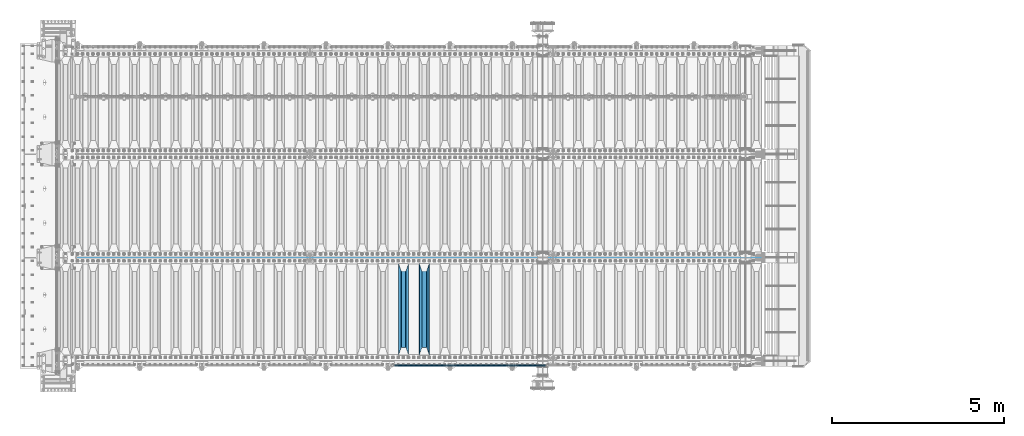
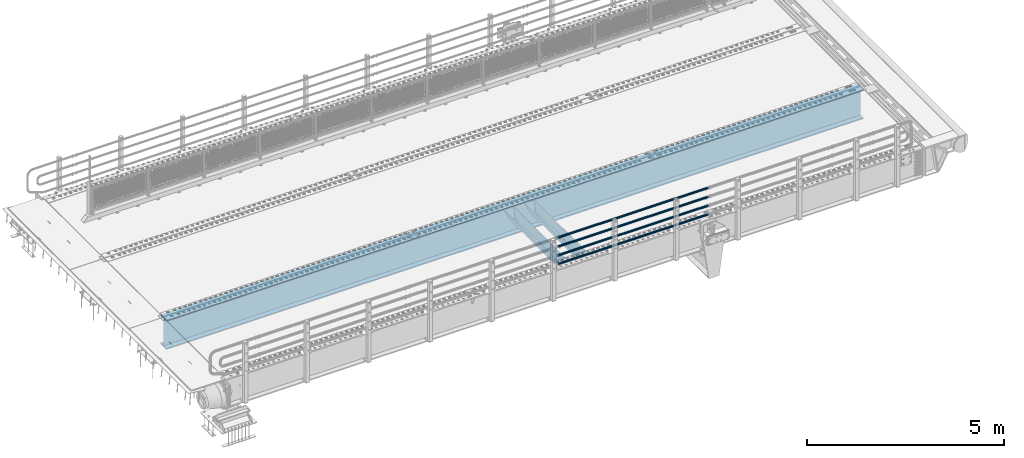
# One storey, part 122 of 270: 7 beams.
"""IFC2X3 building model written with IfcOpenShell, lengths in millimetres."""

from ifc_helpers import new_model, si_unit, frame, origin_with_axes, place, context, subcontext, project, spatial, faceted_brep, material, type_object, element, save


model = new_model("IFC2X3")

# Units and contexts
model_context = context("Model", 3, precision=1e-05, world=origin_with_axes())
body_context = subcontext(model_context, "Body", "Model", "MODEL_VIEW")
ifc_project = project(units=[si_unit("LENGTHUNIT", "METRE", prefix="MILLI"), si_unit("AREAUNIT", "SQUARE_METRE"), si_unit("VOLUMEUNIT", "CUBIC_METRE"), si_unit("MASSUNIT", "GRAM", prefix="KILO"), si_unit("TIMEUNIT", "SECOND"), si_unit("PLANEANGLEUNIT", "RADIAN"), si_unit("SOLIDANGLEUNIT", "STERADIAN"), si_unit("THERMODYNAMICTEMPERATUREUNIT", "DEGREE_CELSIUS"), si_unit("LUMINOUSINTENSITYUNIT", "LUMEN")], contexts=[model_context])

# Site, building, storey
site_placement = place(None, origin_with_axes())
site = spatial("IfcSite", under=ifc_project, at=site_placement, CompositionType="ELEMENT")
building_placement = place(site_placement, origin_with_axes())
building = spatial("IfcBuilding", under=site, at=building_placement, Name="Standard", CompositionType="ELEMENT")
storey_placement = place(building_placement, origin_with_axes())
storey = spatial("IfcBuildingStorey", under=building, at=storey_placement, Name="Undefined", CompositionType="ELEMENT", Elevation=0.0)

# Beams
ifc_material_1 = material()
beam_type_1 = type_object("IfcBeamType", PredefinedType="NOTDEFINED")
beam_1_placement = place(storey_placement, frame((14121.9999999999, -24129.8499999998, 149.849999999726), z_axis=(0.0, 0.0, -1.0), x_axis=(-1.0, 0.0, 0.0)))
element("IfcBeam", 1, at=beam_1_placement, inside=storey, type_object=beam_type_1, material=ifc_material_1, context=body_context, shape_type="Brep", body=[
    faceted_brep([(0.0, -26.5499999999993, 0.0), (0.0, -24.5290015881747, 10.1602451292931), (4384.0, -24.5290015881747, 10.1602451292931), (4384.0, -26.5499999999993, 0.0), (0.0, -18.7736850405036, 18.7736850405028), (4384.0, -18.7736850405036, 18.7736850405028), (0.0, -10.1602451292929, 24.5290015881747), (4384.0, -10.1602451292929, 24.5290015881747), (0.0, 0.0, 26.55), (4384.0, 0.0, 26.55), (0.0, 10.1602451292929, 24.5290015881747), (4384.0, 10.1602451292929, 24.5290015881747), (0.0, 18.7736850405036, 18.7736850405028), (4384.0, 18.7736850405036, 18.7736850405028), (0.0, 24.5290015881747, 10.1602451292931), (4384.0, 24.5290015881747, 10.1602451292931), (0.0, 26.5499999999993, 0.0), (4384.0, 26.5499999999993, 0.0), (0.0, 24.5290015881747, -10.1602451292931), (4384.0, 24.5290015881747, -10.1602451292931), (0.0, 18.7736850405036, -18.7736850405028), (4384.0, 18.7736850405036, -18.7736850405028), (0.0, 10.1602451292929, -24.5290015881747), (4384.0, 10.1602451292929, -24.5290015881747), (0.0, 0.0, -26.55), (4384.0, 0.0, -26.55), (0.0, -10.1602451292929, -24.5290015881747), (4384.0, -10.1602451292929, -24.5290015881747), (0.0, -18.7736850405036, -18.7736850405028), (4384.0, -18.7736850405036, -18.7736850405028), (0.0, -24.5290015881747, -10.1602451292931), (4384.0, -24.5290015881747, -10.1602451292931), (0.0, -30.1499999999996, 0.0), (0.0, -27.8549679052157, -11.5379054858058), (4384.0, -27.8549679052157, -11.5379054858075), (4384.0, -30.1499999999996, 0.0), (0.0, -21.3192694527752, -21.3192694527752), (4384.0, -21.3192694527752, -21.3192694527744), (0.0, -11.5379054858076, -27.8549679052157), (4384.0, -11.5379054858076, -27.8549679052153), (0.0, 0.0, -30.1500000000015), (4384.0, 0.0, -30.15), (0.0, 11.5379054858076, -27.8549679052157), (4384.0, 11.5379054858076, -27.8549679052153), (0.0, 21.3192694527752, -21.3192694527752), (4384.0, 21.3192694527752, -21.3192694527744), (0.0, 27.8549679052157, -11.5379054858058), (4384.0, 27.8549679052157, -11.5379054858074), (0.0, 30.1499999999996, 0.0), (4384.0, 30.1499999999996, 0.0), (0.0, 27.8549679052157, 11.5379054858058), (4384.0, 27.8549679052157, 11.5379054858075), (0.0, 21.3192694527752, 21.3192694527752), (4384.0, 21.3192694527752, 21.3192694527744), (0.0, 11.5379054858076, 27.8549679052157), (4384.0, 11.5379054858076, 27.8549679052153), (0.0, 0.0, 30.1500000000015), (4384.0, 0.0, 30.15), (0.0, -11.5379054858076, 27.8549679052157), (4384.0, -11.5379054858076, 27.8549679052153), (0.0, -21.3192694527752, 21.3192694527752), (4384.0, -21.3192694527752, 21.3192694527744), (0.0, -27.8549679052157, 11.5379054858058), (4384.0, -27.8549679052157, 11.5379054858075)], [[[0, 1, 2, 3]], [[1, 4, 5, 2]], [[4, 6, 7, 5]], [[6, 8, 9, 7]], [[8, 10, 11, 9]], [[10, 12, 13, 11]], [[12, 14, 15, 13]], [[14, 16, 17, 15]], [[16, 18, 19, 17]], [[18, 20, 21, 19]], [[20, 22, 23, 21]], [[22, 24, 25, 23]], [[24, 26, 27, 25]], [[26, 28, 29, 27]], [[28, 30, 31, 29]], [[30, 0, 3, 31]], [[32, 33, 34, 35]], [[33, 36, 37, 34]], [[36, 38, 39, 37]], [[38, 40, 41, 39]], [[40, 42, 43, 41]], [[42, 44, 45, 43]], [[44, 46, 47, 45]], [[46, 48, 49, 47]], [[48, 50, 51, 49]], [[50, 52, 53, 51]], [[52, 54, 55, 53]], [[54, 56, 57, 55]], [[56, 58, 59, 57]], [[58, 60, 61, 59]], [[60, 62, 63, 61]], [[62, 32, 35, 63]], [[37, 39, 41, 43, 45, 47, 49, 51, 53, 55, 57, 59, 61, 63, 35, 34], [5, 7, 9, 11, 13, 15, 17, 19, 21, 23, 25, 27, 29, 31, 3, 2]], [[62, 60, 58, 56, 54, 52, 50, 48, 46, 44, 42, 40, 38, 36, 33, 32], [30, 28, 26, 24, 22, 20, 18, 16, 14, 12, 10, 8, 6, 4, 1, 0]]]),
])
beam_2_placement = place(storey_placement, frame((14121.9999999999, -24129.8499999998, 420.149999999729), z_axis=(0.0, 0.0, -1.0), x_axis=(-1.0, 0.0, 0.0)))
element("IfcBeam", 2, at=beam_2_placement, inside=storey, type_object=beam_type_1, material=ifc_material_1, context=body_context, shape_type="Brep", body=[
    faceted_brep([(0.0, -26.5499999999993, 0.0), (0.0, -24.5290015881747, 10.1602451292931), (4384.0, -24.5290015881747, 10.1602451292931), (4384.0, -26.5499999999993, 0.0), (0.0, -18.7736850405036, 18.7736850405028), (4384.0, -18.7736850405036, 18.7736850405028), (0.0, -10.1602451292929, 24.5290015881747), (4384.0, -10.1602451292929, 24.5290015881747), (0.0, 0.0, 26.55), (4384.0, 0.0, 26.55), (0.0, 10.1602451292929, 24.5290015881747), (4384.0, 10.1602451292929, 24.5290015881747), (0.0, 18.7736850405036, 18.7736850405028), (4384.0, 18.7736850405036, 18.7736850405028), (0.0, 24.5290015881747, 10.1602451292931), (4384.0, 24.5290015881747, 10.1602451292931), (0.0, 26.5499999999993, 0.0), (4384.0, 26.5499999999993, 0.0), (0.0, 24.5290015881747, -10.1602451292931), (4384.0, 24.5290015881747, -10.1602451292931), (0.0, 18.7736850405036, -18.7736850405028), (4384.0, 18.7736850405036, -18.7736850405028), (0.0, 10.1602451292929, -24.5290015881747), (4384.0, 10.1602451292929, -24.5290015881747), (0.0, 0.0, -26.55), (4384.0, 0.0, -26.55), (0.0, -10.1602451292929, -24.5290015881747), (4384.0, -10.1602451292929, -24.5290015881747), (0.0, -18.7736850405036, -18.7736850405028), (4384.0, -18.7736850405036, -18.7736850405028), (0.0, -24.5290015881747, -10.1602451292931), (4384.0, -24.5290015881747, -10.1602451292931), (0.0, -30.1499999999996, 0.0), (0.0, -27.8549679052157, -11.5379054858058), (4384.0, -27.8549679052157, -11.5379054858075), (4384.0, -30.1499999999996, 0.0), (0.0, -21.3192694527752, -21.3192694527752), (4384.0, -21.3192694527752, -21.3192694527744), (0.0, -11.5379054858076, -27.8549679052157), (4384.0, -11.5379054858076, -27.8549679052153), (0.0, 0.0, -30.1500000000015), (4384.0, 0.0, -30.15), (0.0, 11.5379054858076, -27.8549679052157), (4384.0, 11.5379054858076, -27.8549679052153), (0.0, 21.3192694527752, -21.3192694527752), (4384.0, 21.3192694527752, -21.3192694527744), (0.0, 27.8549679052157, -11.5379054858058), (4384.0, 27.8549679052157, -11.5379054858074), (0.0, 30.1499999999996, 0.0), (4384.0, 30.1499999999996, 0.0), (0.0, 27.8549679052157, 11.5379054858058), (4384.0, 27.8549679052157, 11.5379054858075), (0.0, 21.3192694527752, 21.3192694527752), (4384.0, 21.3192694527752, 21.3192694527744), (0.0, 11.5379054858076, 27.8549679052157), (4384.0, 11.5379054858076, 27.8549679052153), (0.0, 0.0, 30.1500000000015), (4384.0, 0.0, 30.15), (0.0, -11.5379054858076, 27.8549679052157), (4384.0, -11.5379054858076, 27.8549679052153), (0.0, -21.3192694527752, 21.3192694527752), (4384.0, -21.3192694527752, 21.3192694527744), (0.0, -27.8549679052157, 11.5379054858058), (4384.0, -27.8549679052157, 11.5379054858075)], [[[0, 1, 2, 3]], [[1, 4, 5, 2]], [[4, 6, 7, 5]], [[6, 8, 9, 7]], [[8, 10, 11, 9]], [[10, 12, 13, 11]], [[12, 14, 15, 13]], [[14, 16, 17, 15]], [[16, 18, 19, 17]], [[18, 20, 21, 19]], [[20, 22, 23, 21]], [[22, 24, 25, 23]], [[24, 26, 27, 25]], [[26, 28, 29, 27]], [[28, 30, 31, 29]], [[30, 0, 3, 31]], [[32, 33, 34, 35]], [[33, 36, 37, 34]], [[36, 38, 39, 37]], [[38, 40, 41, 39]], [[40, 42, 43, 41]], [[42, 44, 45, 43]], [[44, 46, 47, 45]], [[46, 48, 49, 47]], [[48, 50, 51, 49]], [[50, 52, 53, 51]], [[52, 54, 55, 53]], [[54, 56, 57, 55]], [[56, 58, 59, 57]], [[58, 60, 61, 59]], [[60, 62, 63, 61]], [[62, 32, 35, 63]], [[37, 39, 41, 43, 45, 47, 49, 51, 53, 55, 57, 59, 61, 63, 35, 34], [5, 7, 9, 11, 13, 15, 17, 19, 21, 23, 25, 27, 29, 31, 3, 2]], [[62, 60, 58, 56, 54, 52, 50, 48, 46, 44, 42, 40, 38, 36, 33, 32], [30, 28, 26, 24, 22, 20, 18, 16, 14, 12, 10, 8, 6, 4, 1, 0]]]),
])
beam_3_placement = place(storey_placement, frame((14121.9999999999, -24129.8499999998, 969.849999999726), z_axis=(0.0, 0.0, -1.0), x_axis=(-1.0, 0.0, 0.0)))
element("IfcBeam", 3, at=beam_3_placement, inside=storey, type_object=beam_type_1, material=ifc_material_1, context=body_context, shape_type="Brep", body=[
    faceted_brep([(0.0, -26.5499999999993, 0.0), (0.0, -24.5290015881747, 10.1602451292931), (4384.0, -24.5290015881747, 10.1602451292931), (4384.0, -26.5499999999993, 0.0), (0.0, -18.7736850405036, 18.7736850405028), (4384.0, -18.7736850405036, 18.7736850405028), (0.0, -10.1602451292929, 24.5290015881747), (4384.0, -10.1602451292929, 24.5290015881747), (0.0, 0.0, 26.55), (4384.0, 0.0, 26.55), (0.0, 10.1602451292929, 24.5290015881747), (4384.0, 10.1602451292929, 24.5290015881747), (0.0, 18.7736850405036, 18.7736850405028), (4384.0, 18.7736850405036, 18.7736850405028), (0.0, 24.5290015881747, 10.1602451292931), (4384.0, 24.5290015881747, 10.1602451292931), (0.0, 26.5499999999993, 0.0), (4384.0, 26.5499999999993, 0.0), (0.0, 24.5290015881747, -10.1602451292931), (4384.0, 24.5290015881747, -10.1602451292931), (0.0, 18.7736850405036, -18.7736850405028), (4384.0, 18.7736850405036, -18.7736850405028), (0.0, 10.1602451292929, -24.5290015881747), (4384.0, 10.1602451292929, -24.5290015881747), (0.0, 0.0, -26.55), (4384.0, 0.0, -26.55), (0.0, -10.1602451292929, -24.5290015881747), (4384.0, -10.1602451292929, -24.5290015881747), (0.0, -18.7736850405036, -18.7736850405028), (4384.0, -18.7736850405036, -18.7736850405028), (0.0, -24.5290015881747, -10.1602451292931), (4384.0, -24.5290015881747, -10.1602451292931), (0.0, -30.1499999999996, 0.0), (0.0, -27.8549679052157, -11.5379054858058), (4384.0, -27.8549679052157, -11.5379054858075), (4384.0, -30.1499999999996, 0.0), (0.0, -21.3192694527752, -21.3192694527752), (4384.0, -21.3192694527752, -21.3192694527744), (0.0, -11.5379054858076, -27.8549679052157), (4384.0, -11.5379054858076, -27.8549679052153), (0.0, 0.0, -30.1500000000015), (4384.0, 0.0, -30.15), (0.0, 11.5379054858076, -27.8549679052157), (4384.0, 11.5379054858076, -27.8549679052153), (0.0, 21.3192694527752, -21.3192694527752), (4384.0, 21.3192694527752, -21.3192694527744), (0.0, 27.8549679052157, -11.5379054858058), (4384.0, 27.8549679052157, -11.5379054858074), (0.0, 30.1499999999996, 0.0), (4384.0, 30.1499999999996, 0.0), (0.0, 27.8549679052157, 11.5379054858058), (4384.0, 27.8549679052157, 11.5379054858075), (0.0, 21.3192694527752, 21.3192694527752), (4384.0, 21.3192694527752, 21.3192694527744), (0.0, 11.5379054858076, 27.8549679052157), (4384.0, 11.5379054858076, 27.8549679052153), (0.0, 0.0, 30.1500000000015), (4384.0, 0.0, 30.15), (0.0, -11.5379054858076, 27.8549679052157), (4384.0, -11.5379054858076, 27.8549679052153), (0.0, -21.3192694527752, 21.3192694527752), (4384.0, -21.3192694527752, 21.3192694527744), (0.0, -27.8549679052157, 11.5379054858058), (4384.0, -27.8549679052157, 11.5379054858075)], [[[0, 1, 2, 3]], [[1, 4, 5, 2]], [[4, 6, 7, 5]], [[6, 8, 9, 7]], [[8, 10, 11, 9]], [[10, 12, 13, 11]], [[12, 14, 15, 13]], [[14, 16, 17, 15]], [[16, 18, 19, 17]], [[18, 20, 21, 19]], [[20, 22, 23, 21]], [[22, 24, 25, 23]], [[24, 26, 27, 25]], [[26, 28, 29, 27]], [[28, 30, 31, 29]], [[30, 0, 3, 31]], [[32, 33, 34, 35]], [[33, 36, 37, 34]], [[36, 38, 39, 37]], [[38, 40, 41, 39]], [[40, 42, 43, 41]], [[42, 44, 45, 43]], [[44, 46, 47, 45]], [[46, 48, 49, 47]], [[48, 50, 51, 49]], [[50, 52, 53, 51]], [[52, 54, 55, 53]], [[54, 56, 57, 55]], [[56, 58, 59, 57]], [[58, 60, 61, 59]], [[60, 62, 63, 61]], [[62, 32, 35, 63]], [[37, 39, 41, 43, 45, 47, 49, 51, 53, 55, 57, 59, 61, 63, 35, 34], [5, 7, 9, 11, 13, 15, 17, 19, 21, 23, 25, 27, 29, 31, 3, 2]], [[62, 60, 58, 56, 54, 52, 50, 48, 46, 44, 42, 40, 38, 36, 33, 32], [30, 28, 26, 24, 22, 20, 18, 16, 14, 12, 10, 8, 6, 4, 1, 0]]]),
])
beam_4_placement = place(storey_placement, frame((14121.9999999999, -24129.8499999998, 689.849999999726), z_axis=(0.0, 0.0, -1.0), x_axis=(-1.0, 0.0, 0.0)))
element("IfcBeam", 4, at=beam_4_placement, inside=storey, type_object=beam_type_1, material=ifc_material_1, context=body_context, shape_type="Brep", body=[
    faceted_brep([(0.0, -26.5499999999993, 0.0), (0.0, -24.5290015881747, 10.1602451292931), (4384.0, -24.5290015881747, 10.1602451292931), (4384.0, -26.5499999999993, 0.0), (0.0, -18.7736850405036, 18.7736850405028), (4384.0, -18.7736850405036, 18.7736850405028), (0.0, -10.1602451292929, 24.5290015881747), (4384.0, -10.1602451292929, 24.5290015881747), (0.0, 0.0, 26.55), (4384.0, 0.0, 26.55), (0.0, 10.1602451292929, 24.5290015881747), (4384.0, 10.1602451292929, 24.5290015881747), (0.0, 18.7736850405036, 18.7736850405028), (4384.0, 18.7736850405036, 18.7736850405028), (0.0, 24.5290015881747, 10.1602451292931), (4384.0, 24.5290015881747, 10.1602451292931), (0.0, 26.5499999999993, 0.0), (4384.0, 26.5499999999993, 0.0), (0.0, 24.5290015881747, -10.1602451292931), (4384.0, 24.5290015881747, -10.1602451292931), (0.0, 18.7736850405036, -18.7736850405028), (4384.0, 18.7736850405036, -18.7736850405028), (0.0, 10.1602451292929, -24.5290015881747), (4384.0, 10.1602451292929, -24.5290015881747), (0.0, 0.0, -26.55), (4384.0, 0.0, -26.55), (0.0, -10.1602451292929, -24.5290015881747), (4384.0, -10.1602451292929, -24.5290015881747), (0.0, -18.7736850405036, -18.7736850405028), (4384.0, -18.7736850405036, -18.7736850405028), (0.0, -24.5290015881747, -10.1602451292931), (4384.0, -24.5290015881747, -10.1602451292931), (0.0, -30.1499999999996, 0.0), (0.0, -27.8549679052157, -11.5379054858058), (4384.0, -27.8549679052157, -11.5379054858075), (4384.0, -30.1499999999996, 0.0), (0.0, -21.3192694527752, -21.3192694527752), (4384.0, -21.3192694527752, -21.3192694527744), (0.0, -11.5379054858076, -27.8549679052157), (4384.0, -11.5379054858076, -27.8549679052153), (0.0, 0.0, -30.1500000000015), (4384.0, 0.0, -30.15), (0.0, 11.5379054858076, -27.8549679052157), (4384.0, 11.5379054858076, -27.8549679052153), (0.0, 21.3192694527752, -21.3192694527752), (4384.0, 21.3192694527752, -21.3192694527744), (0.0, 27.8549679052157, -11.5379054858058), (4384.0, 27.8549679052157, -11.5379054858074), (0.0, 30.1499999999996, 0.0), (4384.0, 30.1499999999996, 0.0), (0.0, 27.8549679052157, 11.5379054858058), (4384.0, 27.8549679052157, 11.5379054858075), (0.0, 21.3192694527752, 21.3192694527752), (4384.0, 21.3192694527752, 21.3192694527744), (0.0, 11.5379054858076, 27.8549679052157), (4384.0, 11.5379054858076, 27.8549679052153), (0.0, 0.0, 30.1500000000015), (4384.0, 0.0, 30.15), (0.0, -11.5379054858076, 27.8549679052157), (4384.0, -11.5379054858076, 27.8549679052153), (0.0, -21.3192694527752, 21.3192694527752), (4384.0, -21.3192694527752, 21.3192694527744), (0.0, -27.8549679052157, 11.5379054858058), (4384.0, -27.8549679052157, 11.5379054858075)], [[[0, 1, 2, 3]], [[1, 4, 5, 2]], [[4, 6, 7, 5]], [[6, 8, 9, 7]], [[8, 10, 11, 9]], [[10, 12, 13, 11]], [[12, 14, 15, 13]], [[14, 16, 17, 15]], [[16, 18, 19, 17]], [[18, 20, 21, 19]], [[20, 22, 23, 21]], [[22, 24, 25, 23]], [[24, 26, 27, 25]], [[26, 28, 29, 27]], [[28, 30, 31, 29]], [[30, 0, 3, 31]], [[32, 33, 34, 35]], [[33, 36, 37, 34]], [[36, 38, 39, 37]], [[38, 40, 41, 39]], [[40, 42, 43, 41]], [[42, 44, 45, 43]], [[44, 46, 47, 45]], [[46, 48, 49, 47]], [[48, 50, 51, 49]], [[50, 52, 53, 51]], [[52, 54, 55, 53]], [[54, 56, 57, 55]], [[56, 58, 59, 57]], [[58, 60, 61, 59]], [[60, 62, 63, 61]], [[62, 32, 35, 63]], [[37, 39, 41, 43, 45, 47, 49, 51, 53, 55, 57, 59, 61, 63, 35, 34], [5, 7, 9, 11, 13, 15, 17, 19, 21, 23, 25, 27, 29, 31, 3, 2]], [[62, 60, 58, 56, 54, 52, 50, 48, 46, 44, 42, 40, 38, 36, 33, 32], [30, 28, 26, 24, 22, 20, 18, 16, 14, 12, 10, 8, 6, 4, 1, 0]]]),
])
ifc_material_2 = material(Name="STEEL/S355N")
beam_type_2 = type_object("IfcBeamType", PredefinedType="NOTDEFINED")
beam_5_placement = place(storey_placement, frame((10600.0, -23825.0, -115.0), z_axis=(0.0, 0.0, 1.0), x_axis=(0.0, 1.0, 0.0)))
element("IfcBeam", 5, at=beam_5_placement, inside=storey, type_object=beam_type_2, material=ifc_material_2, context=body_context, shape_type="Brep", body=[
    faceted_brep([(0.0, 150.0, 115.0), (0.0, 143.689999999999, 115.0), (2650.00000000297, 143.689999999999, 115.0), (2650.00000000297, 150.0, 115.0), (2650.00000000297, 142.059565218398, 110.000000003096), (2650.00000000297, 148.3695652184, 110.000000003096), (2441.90079219209, -80.1103600731112, -98.0992078077845), (2437.7588105432, -77.5672621345584, -102.241189456673), (2434.06523489747, -74.4080125315522, -105.934765102404), (2430.9108609509, -70.710272125576, -109.089139048974), (2428.37322971128, -66.5649389910068, -111.626770288588), (2426.51472138055, -62.0739139532889, -113.485278619323), (2425.38102192092, -57.3475956567672, -114.618978078955), (2424.99999999987, -52.5021667386536, -115.0), (2424.99999999987, 52.5021667386536, -115.0), (2425.38102192092, 57.3475956567672, -114.618978078955), (2426.51472138055, 62.0739139532889, -113.485278619323), (2428.37322971128, 66.5649389910068, -111.626770288588), (2430.9108609509, 70.710272125576, -109.089139048974), (2434.06523489747, 74.4080125315522, -105.934765102404), (2437.7588105432, 77.5672621345584, -102.241189456673), (2441.90079219209, 80.1103600731112, -98.0992078077846), (2446.38936140511, 81.9747917625791, -93.6106385947584), (2448.2494850041, 76.2713538057251, -91.7505149957729), (2444.62967112263, 74.76777986261, -95.3703288772456), (2441.28936334126, 72.7168944282894, -98.710636658607), (2438.31067330439, 70.1691124903846, -101.689326695487), (2435.76682334747, 67.1870637758839, -104.233176652398), (2433.72034654133, 63.8440531834895, -106.279653458539), (2432.22154950042, 60.222258798236, -107.778450499454), (2431.30727574265, 56.4107117849089, -108.692724257221), (2430.99999999987, 52.5031078186876, -109.0), (2430.99999999987, -52.5031078186876, -109.0), (2431.30727574265, -56.4107117849089, -108.692724257221), (2432.22154950042, -60.222258798236, -107.778450499454), (2433.72034654133, -63.8440531834895, -106.279653458539), (2435.76682334747, -67.1870637758839, -104.233176652398), (2438.31067330438, -70.1691124903846, -101.689326695487), (2441.28936334126, -72.7168944282894, -98.7106366586071), (2444.62967112263, -74.76777986261, -95.3703288772457), (2448.2494850041, -76.2713538057251, -91.7505149957729), (2650.00000000297, -142.059565218398, 110.000000003096), (2650.00000000297, -148.3695652184, 110.000000003096), (2446.38936140511, -81.9747917625791, -93.6106385947584), (2650.00000000297, -143.689999999999, 115.0), (2650.00000000297, -150.0, 115.0), (0.0, -143.689999999999, 115.0), (0.0, -150.0, 115.0), (0.0, -148.369565218261, 110.000000002672), (203.610638597431, -81.9747917625791, -93.6106385947584), (208.099207810457, -80.1103600731112, -98.0992078077845), (212.241189459342, -77.5672621345584, -102.241189456673), (215.934765105078, -74.4080125315522, -105.934765102404), (219.089139051644, -70.710272125576, -109.089139048974), (221.626770291259, -66.5649389910068, -111.626770288588), (223.485278621993, -62.0739139532889, -113.485278619323), (224.618978081628, -57.3475956567672, -114.618978078955), (225.00000000267, -52.5021667386536, -115.0), (225.00000000267, 52.5021667386536, -115.0), (224.618978081628, 57.3475956567672, -114.618978078955), (223.485278621993, 62.0739139532889, -113.485278619323), (221.626770291259, 66.5649389910068, -111.626770288588), (219.089139051644, 70.710272125576, -109.089139048974), (215.934765105078, 74.4080125315522, -105.934765102404), (212.241189459342, 77.5672621345584, -102.241189456673), (208.099207810457, 80.1103600731112, -98.0992078077846), (203.610638597431, 81.9747917625791, -93.6106385947584), (0.0, 148.369565218261, 110.000000002672), (0.0, 142.05956521826, 110.000000002672), (201.750514998446, 76.2713538057251, -91.7505149957729), (205.370328879915, 74.76777986261, -95.3703288772456), (208.710636661279, 72.7168944282894, -98.710636658607), (211.689326698157, 70.1691124903846, -101.689326695487), (214.233176655071, 67.1870637758839, -104.233176652398), (216.27965346121, 63.8440531834895, -106.279653458539), (217.778450502126, 60.222258798236, -107.778450499454), (218.692724259894, 56.4107117849089, -108.692724257221), (219.00000000267, 52.5031078186876, -109.0), (219.00000000267, -52.5031078186876, -109.0), (218.692724259894, -56.4107117849089, -108.692724257221), (217.778450502123, -60.222258798236, -107.778450499454), (216.27965346121, -63.8440531834895, -106.279653458539), (214.233176655071, -67.1870637758839, -104.233176652398), (211.689326698157, -70.1691124903846, -101.689326695487), (208.710636661279, -72.7168944282894, -98.7106366586071), (205.370328879915, -74.76777986261, -95.3703288772457), (201.750514998446, -76.2713538057251, -91.7505149957729), (0.0, -142.05956521826, 110.000000002672)], [[[0, 1, 2, 3]], [[3, 2, 4, 5]], [[6, 7, 8, 9, 10, 11, 12, 13, 14, 15, 16, 17, 18, 19, 20, 21, 22, 5, 4, 23, 24, 25, 26, 27, 28, 29, 30, 31, 32, 33, 34, 35, 36, 37, 38, 39, 40, 41, 42, 43]], [[44, 45, 42, 41]], [[46, 47, 45, 44]], [[43, 42, 45, 47, 48, 49]], [[6, 43, 49, 50]], [[7, 6, 50, 51]], [[8, 7, 51, 52]], [[9, 8, 52, 53]], [[10, 9, 53, 54]], [[11, 10, 54, 55]], [[12, 11, 55, 56]], [[13, 12, 56, 57]], [[14, 13, 57, 58]], [[15, 14, 58, 59]], [[16, 15, 59, 60]], [[17, 16, 60, 61]], [[18, 17, 61, 62]], [[19, 18, 62, 63]], [[20, 19, 63, 64]], [[21, 20, 64, 65]], [[22, 21, 65, 66]], [[0, 3, 5, 22, 66, 67]], [[1, 0, 67, 68]], [[23, 4, 2, 1, 68, 69]], [[24, 23, 69, 70]], [[25, 24, 70, 71]], [[26, 25, 71, 72]], [[27, 26, 72, 73]], [[28, 27, 73, 74]], [[29, 28, 74, 75]], [[30, 29, 75, 76]], [[31, 30, 76, 77]], [[32, 31, 77, 78]], [[33, 32, 78, 79]], [[34, 33, 79, 80]], [[35, 34, 80, 81]], [[36, 35, 81, 82]], [[37, 36, 82, 83]], [[38, 37, 83, 84]], [[39, 38, 84, 85]], [[40, 39, 85, 86]], [[46, 44, 41, 40, 86, 87]], [[47, 46, 87, 48]], [[86, 85, 84, 83, 82, 81, 80, 79, 78, 77, 76, 75, 74, 73, 72, 71, 70, 69, 68, 67, 66, 65, 64, 63, 62, 61, 60, 59, 58, 57, 56, 55, 54, 53, 52, 51, 50, 49, 48, 87]]]),
])
beam_6_placement = place(storey_placement, frame((10000.0, -23825.0, -115.0), z_axis=(0.0, 0.0, 1.0), x_axis=(0.0, 1.0, 0.0)))
element("IfcBeam", 6, at=beam_6_placement, inside=storey, type_object=beam_type_2, material=ifc_material_2, context=body_context, shape_type="Brep", body=[
    faceted_brep([(0.0, 150.0, 115.0), (0.0, 143.689999999999, 115.0), (2650.00000000297, 143.689999999999, 115.0), (2650.00000000297, 150.0, 115.0), (2650.00000000297, 142.059565218398, 110.000000003096), (2650.00000000297, 148.3695652184, 110.000000003096), (2441.90079219209, -80.1103600731112, -98.0992078077845), (2437.7588105432, -77.5672621345584, -102.241189456673), (2434.06523489747, -74.4080125315522, -105.934765102404), (2430.9108609509, -70.710272125576, -109.089139048974), (2428.37322971128, -66.5649389910068, -111.626770288588), (2426.51472138055, -62.0739139532889, -113.485278619323), (2425.38102192092, -57.3475956567672, -114.618978078955), (2424.99999999987, -52.5021667386536, -115.0), (2424.99999999987, 52.5021667386536, -115.0), (2425.38102192092, 57.3475956567672, -114.618978078955), (2426.51472138055, 62.0739139532889, -113.485278619323), (2428.37322971128, 66.5649389910068, -111.626770288588), (2430.9108609509, 70.710272125576, -109.089139048974), (2434.06523489747, 74.4080125315522, -105.934765102404), (2437.7588105432, 77.5672621345584, -102.241189456673), (2441.90079219209, 80.1103600731112, -98.0992078077846), (2446.38936140511, 81.9747917625791, -93.6106385947584), (2448.2494850041, 76.2713538057251, -91.7505149957729), (2444.62967112263, 74.76777986261, -95.3703288772456), (2441.28936334126, 72.7168944282894, -98.710636658607), (2438.31067330439, 70.1691124903846, -101.689326695487), (2435.76682334747, 67.1870637758839, -104.233176652398), (2433.72034654133, 63.8440531834895, -106.279653458539), (2432.22154950042, 60.222258798236, -107.778450499454), (2431.30727574265, 56.4107117849089, -108.692724257221), (2430.99999999987, 52.5031078186876, -109.0), (2430.99999999987, -52.5031078186876, -109.0), (2431.30727574265, -56.4107117849089, -108.692724257221), (2432.22154950042, -60.222258798236, -107.778450499454), (2433.72034654133, -63.8440531834895, -106.279653458539), (2435.76682334747, -67.1870637758839, -104.233176652398), (2438.31067330438, -70.1691124903846, -101.689326695487), (2441.28936334126, -72.7168944282894, -98.7106366586071), (2444.62967112263, -74.76777986261, -95.3703288772457), (2448.2494850041, -76.2713538057251, -91.7505149957729), (2650.00000000297, -142.059565218398, 110.000000003096), (2650.00000000297, -148.3695652184, 110.000000003096), (2446.38936140511, -81.9747917625791, -93.6106385947584), (2650.00000000297, -143.689999999999, 115.0), (2650.00000000297, -150.0, 115.0), (0.0, -143.689999999999, 115.0), (0.0, -150.0, 115.0), (0.0, -148.369565218261, 110.000000002672), (203.610638597431, -81.9747917625791, -93.6106385947584), (208.099207810457, -80.1103600731112, -98.0992078077845), (212.241189459342, -77.5672621345584, -102.241189456673), (215.934765105078, -74.4080125315522, -105.934765102404), (219.089139051644, -70.710272125576, -109.089139048974), (221.626770291259, -66.5649389910068, -111.626770288588), (223.485278621993, -62.0739139532889, -113.485278619323), (224.618978081628, -57.3475956567672, -114.618978078955), (225.00000000267, -52.5021667386536, -115.0), (225.00000000267, 52.5021667386536, -115.0), (224.618978081628, 57.3475956567672, -114.618978078955), (223.485278621993, 62.0739139532889, -113.485278619323), (221.626770291259, 66.5649389910068, -111.626770288588), (219.089139051644, 70.710272125576, -109.089139048974), (215.934765105078, 74.4080125315522, -105.934765102404), (212.241189459342, 77.5672621345584, -102.241189456673), (208.099207810457, 80.1103600731112, -98.0992078077846), (203.610638597431, 81.9747917625791, -93.6106385947584), (0.0, 148.369565218261, 110.000000002672), (0.0, 142.05956521826, 110.000000002672), (201.750514998446, 76.2713538057251, -91.7505149957729), (205.370328879915, 74.76777986261, -95.3703288772456), (208.710636661279, 72.7168944282894, -98.710636658607), (211.689326698157, 70.1691124903846, -101.689326695487), (214.233176655071, 67.1870637758839, -104.233176652398), (216.27965346121, 63.8440531834895, -106.279653458539), (217.778450502126, 60.222258798236, -107.778450499454), (218.692724259894, 56.4107117849089, -108.692724257221), (219.00000000267, 52.5031078186876, -109.0), (219.00000000267, -52.5031078186876, -109.0), (218.692724259894, -56.4107117849089, -108.692724257221), (217.778450502123, -60.222258798236, -107.778450499454), (216.27965346121, -63.8440531834895, -106.279653458539), (214.233176655071, -67.1870637758839, -104.233176652398), (211.689326698157, -70.1691124903846, -101.689326695487), (208.710636661279, -72.7168944282894, -98.7106366586071), (205.370328879915, -74.76777986261, -95.3703288772457), (201.750514998446, -76.2713538057251, -91.7505149957729), (0.0, -142.05956521826, 110.000000002672)], [[[0, 1, 2, 3]], [[3, 2, 4, 5]], [[6, 7, 8, 9, 10, 11, 12, 13, 14, 15, 16, 17, 18, 19, 20, 21, 22, 5, 4, 23, 24, 25, 26, 27, 28, 29, 30, 31, 32, 33, 34, 35, 36, 37, 38, 39, 40, 41, 42, 43]], [[44, 45, 42, 41]], [[46, 47, 45, 44]], [[43, 42, 45, 47, 48, 49]], [[6, 43, 49, 50]], [[7, 6, 50, 51]], [[8, 7, 51, 52]], [[9, 8, 52, 53]], [[10, 9, 53, 54]], [[11, 10, 54, 55]], [[12, 11, 55, 56]], [[13, 12, 56, 57]], [[14, 13, 57, 58]], [[15, 14, 58, 59]], [[16, 15, 59, 60]], [[17, 16, 60, 61]], [[18, 17, 61, 62]], [[19, 18, 62, 63]], [[20, 19, 63, 64]], [[21, 20, 64, 65]], [[22, 21, 65, 66]], [[0, 3, 5, 22, 66, 67]], [[1, 0, 67, 68]], [[23, 4, 2, 1, 68, 69]], [[24, 23, 69, 70]], [[25, 24, 70, 71]], [[26, 25, 71, 72]], [[27, 26, 72, 73]], [[28, 27, 73, 74]], [[29, 28, 74, 75]], [[30, 29, 75, 76]], [[31, 30, 76, 77]], [[32, 31, 77, 78]], [[33, 32, 78, 79]], [[34, 33, 79, 80]], [[35, 34, 80, 81]], [[36, 35, 81, 82]], [[37, 36, 82, 83]], [[38, 37, 83, 84]], [[39, 38, 84, 85]], [[40, 39, 85, 86]], [[46, 44, 41, 40, 86, 87]], [[47, 46, 87, 48]], [[86, 85, 84, 83, 82, 81, 80, 79, 78, 77, 76, 75, 74, 73, 72, 71, 70, 69, 68, 67, 66, 65, 64, 63, 62, 61, 60, 59, 58, 57, 56, 55, 54, 53, 52, 51, 50, 49, 48, 87]]]),
])
beam_type_3 = type_object("IfcBeamType", Name="HEB900", PredefinedType="NOTDEFINED")
beam_7_placement = place(storey_placement, frame((10.0000000000036, -21000.0, -450.0), z_axis=(0.0, 0.0, 1.0), x_axis=(1.0, 0.0, 0.0)))
element("IfcBeam", 7, at=beam_7_placement, inside=storey, type_object=beam_type_3, material=ifc_material_2, ObjectType="HEB900", context=body_context, shape_type="Brep", body=[
    faceted_brep([(0.0, 150.0, -450.0), (0.0, 150.0, -415.0), (20380.0, 150.0, -415.0), (20380.0, 150.0, -450.0), (0.0, 9.25, -415.0), (20380.0, 9.25, -415.0), (0.0, 9.25, 415.0), (20380.0, 9.25, 415.0), (0.0, 150.0, 415.0), (20380.0, 150.0, 415.0), (0.0, 150.0, 450.0), (20380.0, 150.0, 450.0), (0.0, -150.0, 450.0), (20380.0, -150.0, 450.0), (0.0, -150.0, 415.0), (20380.0, -150.0, 415.0), (0.0, -9.25, 415.0), (20380.0, -9.25, 415.0), (0.0, -9.25, -415.0), (20380.0, -9.25, -415.0), (0.0, -150.0, -415.0), (20380.0, -150.0, -415.0), (0.0, -150.0, -450.0), (20380.0, -150.0, -450.0)], [[[0, 1, 2, 3]], [[1, 4, 5, 2]], [[4, 6, 7, 5]], [[6, 8, 9, 7]], [[8, 10, 11, 9]], [[10, 12, 13, 11]], [[12, 14, 15, 13]], [[14, 16, 17, 15]], [[16, 18, 19, 17]], [[18, 20, 21, 19]], [[20, 22, 23, 21]], [[22, 0, 3, 23]], [[5, 7, 9, 11, 13, 15, 17, 19, 21, 23, 3, 2]], [[22, 20, 18, 16, 14, 12, 10, 8, 6, 4, 1, 0]]]),
])

save(model, "model.ifc")
